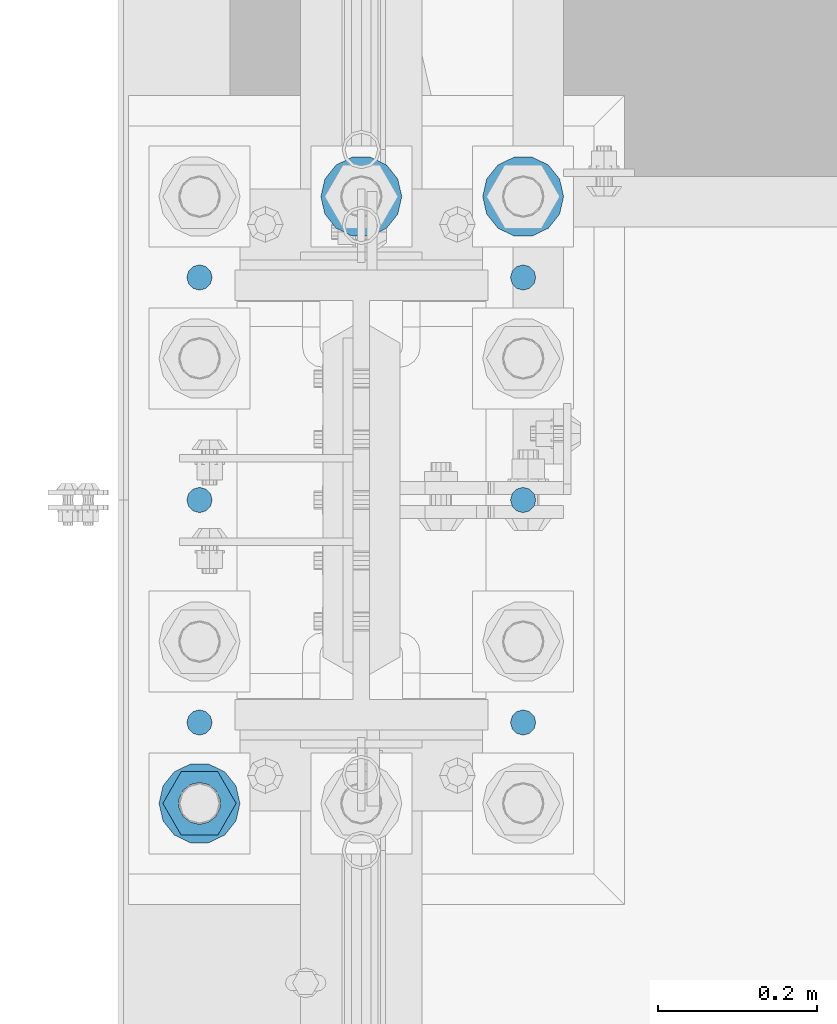
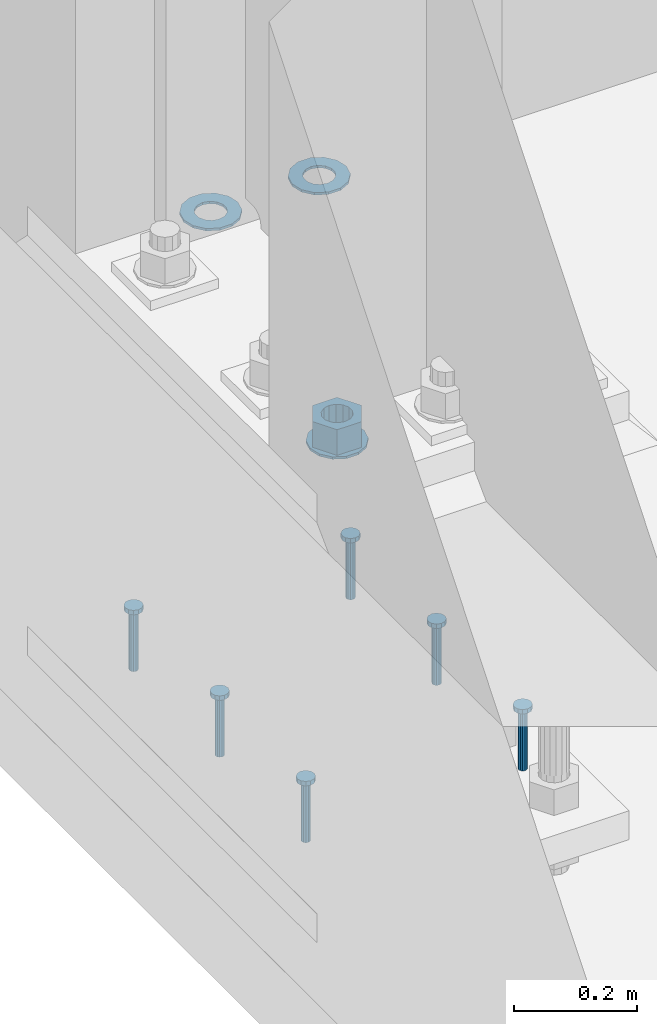
# One storey, part 834 of 1876: 10 columns, 1 element without a shape of its own.
"""IFC2X3 building model written with IfcOpenShell, lengths in millimetres."""

from ifc_helpers import new_model, si_unit, frame, origin_with_axes, place, context, subcontext, project, spatial, faceted_brep, material, type_object, element, aggregate, save


model = new_model("IFC2X3")

# Units and contexts
model_context = context("Model", 3, precision=1e-05, world=origin_with_axes())
body_context = subcontext(model_context, "Body", "Model", "MODEL_VIEW")
ifc_project = project(units=[si_unit("LENGTHUNIT", "METRE", prefix="MILLI"), si_unit("AREAUNIT", "SQUARE_METRE"), si_unit("VOLUMEUNIT", "CUBIC_METRE"), si_unit("MASSUNIT", "GRAM", prefix="KILO"), si_unit("TIMEUNIT", "SECOND"), si_unit("PLANEANGLEUNIT", "RADIAN"), si_unit("SOLIDANGLEUNIT", "STERADIAN"), si_unit("THERMODYNAMICTEMPERATUREUNIT", "DEGREE_CELSIUS"), si_unit("LUMINOUSINTENSITYUNIT", "LUMEN")], contexts=[model_context])

# Site, building, storey
site_placement = place(None, origin_with_axes())
site = spatial("IfcSite", under=ifc_project, at=site_placement, CompositionType="ELEMENT")
building_placement = place(site_placement, origin_with_axes())
building = spatial("IfcBuilding", under=site, at=building_placement, Name="Undefined", CompositionType="ELEMENT")
storey_placement = place(building_placement, origin_with_axes())
storey = spatial("IfcBuildingStorey", under=building, at=storey_placement, Name="Undefined", CompositionType="ELEMENT", Elevation=0.0)

# Assembly, columns
assembly_placement = place(storey_placement, origin_with_axes())
assembly = element("IfcElementAssembly", 1, at=assembly_placement, inside=storey, Name="TEMPLATE", AssemblyPlace="NOTDEFINED", PredefinedType="RIGID_FRAME")
ifc_material_1 = material(Name="STEEL/F436")
column_type_1 = type_object("IfcColumnType", Name="2_WASHER", PredefinedType="NOTDEFINED")
column_1_placement = place(assembly_placement, frame((0.0, 1905.0, 38.1), z_axis=(0.0, -1.0, 0.0), x_axis=(0.0, 0.0, -1.0)))
column_1 = element("IfcColumn", 2, at=column_1_placement, type_object=column_type_1, material=ifc_material_1, Name="WASHER", ObjectType="2_WASHER", context=body_context, shape_type="Brep", body=[
    faceted_brep([(0.0, -50.7999992370605, 9.09494701772928e-13), (0.0, -45.7692178020588, -22.0412936161442), (4.7625, -45.7692178020588, -22.0412936161442), (4.7625, -50.7999992370605, 9.09494701772928e-13), (0.0, -31.6732814587394, -39.7170387128856), (4.7625, -31.6732814587394, -39.7170387128856), (0.0, -11.3040632752118, -49.5263371950259), (4.7625, -11.3040632752118, -49.5263371950259), (0.0, 11.30406327521, -49.5263371950264), (4.7625, 11.30406327521, -49.5263371950264), (0.0, 31.6732814587385, -39.7170387128867), (4.7625, 31.6732814587385, -39.7170387128867), (0.0, 45.7692178020579, -22.041293616146), (4.7625, 45.7692178020579, -22.041293616146), (0.0, 50.7999992370605, -9.09494701772928e-13), (4.7625, 50.7999992370605, -9.09494701772928e-13), (0.0, 45.7692178020588, 22.0412936161442), (4.7625, 45.7692178020588, 22.0412936161442), (0.0, 31.6732814587394, 39.7170387128856), (4.7625, 31.6732814587394, 39.7170387128856), (0.0, 11.3040632752118, 49.5263371950259), (4.7625, 11.3040632752118, 49.5263371950259), (0.0, -11.30406327521, 49.5263371950264), (4.7625, -11.30406327521, 49.5263371950264), (0.0, -31.6732814587385, 39.7170387128867), (4.7625, -31.6732814587385, 39.7170387128867), (0.0, -45.7692178020579, 22.041293616146), (4.7625, -45.7692178020579, 22.041293616146), (0.0, 0.0, 26.9869995117188), (0.0, 11.7093983825444, 24.3146012721213), (4.7625, 11.7093983825444, 24.3146012721213), (4.7625, 0.0, 26.9869995117188), (0.0, 21.0996520289491, 16.8262864224157), (4.7625, 21.0996520289491, 16.8262864224157), (0.0, 26.3108629296712, 6.00524193584533), (4.7625, 26.3108629296712, 6.00524193584533), (0.0, 26.3108629296712, -6.00524193584533), (4.7625, 26.3108629296712, -6.00524193584533), (0.0, 21.0996520289491, -16.8262864224157), (4.7625, 21.0996520289491, -16.8262864224157), (0.0, 11.7093983825444, -24.3146012721213), (4.7625, 11.7093983825444, -24.3146012721213), (0.0, 0.0, -26.9869995117188), (4.7625, 0.0, -26.9869995117188), (0.0, -11.7093983825444, -24.3146012721213), (4.7625, -11.7093983825444, -24.3146012721213), (0.0, -21.0996520289491, -16.8262864224157), (4.7625, -21.0996520289491, -16.8262864224157), (0.0, -26.3108629296712, -6.00524193584533), (4.7625, -26.3108629296712, -6.00524193584533), (0.0, -26.3108629296712, 6.00524193584533), (4.7625, -26.3108629296712, 6.00524193584533), (0.0, -21.0996520289491, 16.8262864224157), (4.7625, -21.0996520289491, 16.8262864224157), (0.0, -11.7093983825444, 24.3146012721213), (4.7625, -11.7093983825444, 24.3146012721213)], [[[0, 1, 2, 3]], [[1, 4, 5, 2]], [[4, 6, 7, 5]], [[6, 8, 9, 7]], [[8, 10, 11, 9]], [[10, 12, 13, 11]], [[12, 14, 15, 13]], [[14, 16, 17, 15]], [[16, 18, 19, 17]], [[18, 20, 21, 19]], [[20, 22, 23, 21]], [[22, 24, 25, 23]], [[24, 26, 27, 25]], [[26, 0, 3, 27]], [[28, 29, 30, 31]], [[29, 32, 33, 30]], [[32, 34, 35, 33]], [[34, 36, 37, 35]], [[36, 38, 39, 37]], [[38, 40, 41, 39]], [[40, 42, 43, 41]], [[42, 44, 45, 43]], [[44, 46, 47, 45]], [[46, 48, 49, 47]], [[48, 50, 51, 49]], [[50, 52, 53, 51]], [[52, 54, 55, 53]], [[54, 28, 31, 55]], [[5, 7, 9, 11, 13, 15, 17, 19, 21, 23, 25, 27, 3, 2], [33, 35, 37, 39, 41, 43, 45, 47, 49, 51, 53, 55, 31, 30]], [[26, 24, 22, 20, 18, 16, 14, 12, 10, 8, 6, 4, 1, 0], [54, 52, 50, 48, 46, 44, 42, 40, 38, 36, 34, 32, 29, 28]]]),
])
column_2_placement = place(assembly_placement, frame((203.2, 1905.0, 38.1), z_axis=(0.0, 1.0, 0.0), x_axis=(0.0, 0.0, -1.0)))
column_2 = element("IfcColumn", 3, at=column_2_placement, type_object=column_type_1, material=ifc_material_1, Name="WASHER", ObjectType="2_WASHER", context=body_context, shape_type="Brep", body=[
    faceted_brep([(0.0, -50.7999992370605, 9.09494701772928e-13), (0.0, -45.7692178020588, -22.0412936161442), (4.7625, -45.7692178020588, -22.0412936161442), (4.7625, -50.7999992370605, 9.09494701772928e-13), (0.0, -31.6732814587394, -39.7170387128856), (4.7625, -31.6732814587394, -39.7170387128856), (0.0, -11.3040632752118, -49.5263371950259), (4.7625, -11.3040632752118, -49.5263371950259), (0.0, 11.30406327521, -49.5263371950264), (4.7625, 11.30406327521, -49.5263371950264), (0.0, 31.6732814587385, -39.7170387128867), (4.7625, 31.6732814587385, -39.7170387128867), (0.0, 45.7692178020579, -22.041293616146), (4.7625, 45.7692178020579, -22.041293616146), (0.0, 50.7999992370605, -9.09494701772928e-13), (4.7625, 50.7999992370605, -9.09494701772928e-13), (0.0, 45.7692178020588, 22.0412936161442), (4.7625, 45.7692178020588, 22.0412936161442), (0.0, 31.6732814587394, 39.7170387128856), (4.7625, 31.6732814587394, 39.7170387128856), (0.0, 11.3040632752118, 49.5263371950259), (4.7625, 11.3040632752118, 49.5263371950259), (0.0, -11.30406327521, 49.5263371950264), (4.7625, -11.30406327521, 49.5263371950264), (0.0, -31.6732814587385, 39.7170387128867), (4.7625, -31.6732814587385, 39.7170387128867), (0.0, -45.7692178020579, 22.041293616146), (4.7625, -45.7692178020579, 22.041293616146), (0.0, 0.0, 26.9869995117188), (0.0, 11.7093983825444, 24.3146012721213), (4.7625, 11.7093983825444, 24.3146012721213), (4.7625, 0.0, 26.9869995117188), (0.0, 21.0996520289491, 16.8262864224157), (4.7625, 21.0996520289491, 16.8262864224157), (0.0, 26.3108629296712, 6.00524193584533), (4.7625, 26.3108629296712, 6.00524193584533), (0.0, 26.3108629296712, -6.00524193584533), (4.7625, 26.3108629296712, -6.00524193584533), (0.0, 21.0996520289491, -16.8262864224157), (4.7625, 21.0996520289491, -16.8262864224157), (0.0, 11.7093983825444, -24.3146012721213), (4.7625, 11.7093983825444, -24.3146012721213), (0.0, 0.0, -26.9869995117188), (4.7625, 0.0, -26.9869995117188), (0.0, -11.7093983825444, -24.3146012721213), (4.7625, -11.7093983825444, -24.3146012721213), (0.0, -21.0996520289491, -16.8262864224157), (4.7625, -21.0996520289491, -16.8262864224157), (0.0, -26.3108629296712, -6.00524193584533), (4.7625, -26.3108629296712, -6.00524193584533), (0.0, -26.3108629296712, 6.00524193584533), (4.7625, -26.3108629296712, 6.00524193584533), (0.0, -21.0996520289491, 16.8262864224157), (4.7625, -21.0996520289491, 16.8262864224157), (0.0, -11.7093983825444, 24.3146012721213), (4.7625, -11.7093983825444, 24.3146012721213)], [[[0, 1, 2, 3]], [[1, 4, 5, 2]], [[4, 6, 7, 5]], [[6, 8, 9, 7]], [[8, 10, 11, 9]], [[10, 12, 13, 11]], [[12, 14, 15, 13]], [[14, 16, 17, 15]], [[16, 18, 19, 17]], [[18, 20, 21, 19]], [[20, 22, 23, 21]], [[22, 24, 25, 23]], [[24, 26, 27, 25]], [[26, 0, 3, 27]], [[28, 29, 30, 31]], [[29, 32, 33, 30]], [[32, 34, 35, 33]], [[34, 36, 37, 35]], [[36, 38, 39, 37]], [[38, 40, 41, 39]], [[40, 42, 43, 41]], [[42, 44, 45, 43]], [[44, 46, 47, 45]], [[46, 48, 49, 47]], [[48, 50, 51, 49]], [[50, 52, 53, 51]], [[52, 54, 55, 53]], [[54, 28, 31, 55]], [[5, 7, 9, 11, 13, 15, 17, 19, 21, 23, 25, 27, 3, 2], [33, 35, 37, 39, 41, 43, 45, 47, 49, 51, 53, 55, 31, 30]], [[26, 24, 22, 20, 18, 16, 14, 12, 10, 8, 6, 4, 1, 0], [54, 52, 50, 48, 46, 44, 42, 40, 38, 36, 34, 32, 29, 28]]]),
])
column_3_placement = place(assembly_placement, frame((-203.2, 1143.0, 119.0625), z_axis=(0.0, -1.0, 0.0), x_axis=(0.0, 0.0, -1.0)))
column_3 = element("IfcColumn", 4, at=column_3_placement, type_object=column_type_1, material=ifc_material_1, Name="WASHER", ObjectType="2_WASHER", context=body_context, shape_type="Brep", body=[
    faceted_brep([(0.0, -50.7999992370605, 9.09494701772928e-13), (0.0, -45.7692178020588, -22.0412936161442), (4.7625, -45.7692178020588, -22.0412936161442), (4.7625, -50.7999992370605, 9.09494701772928e-13), (0.0, -31.6732814587394, -39.7170387128856), (4.7625, -31.6732814587394, -39.7170387128856), (0.0, -11.3040632752118, -49.5263371950259), (4.7625, -11.3040632752118, -49.5263371950259), (0.0, 11.30406327521, -49.5263371950264), (4.7625, 11.30406327521, -49.5263371950264), (0.0, 31.6732814587385, -39.7170387128867), (4.7625, 31.6732814587385, -39.7170387128867), (0.0, 45.7692178020579, -22.041293616146), (4.7625, 45.7692178020579, -22.041293616146), (0.0, 50.7999992370605, -9.09494701772928e-13), (4.7625, 50.7999992370605, -9.09494701772928e-13), (0.0, 45.7692178020588, 22.0412936161442), (4.7625, 45.7692178020588, 22.0412936161442), (0.0, 31.6732814587394, 39.7170387128856), (4.7625, 31.6732814587394, 39.7170387128856), (0.0, 11.3040632752118, 49.5263371950259), (4.7625, 11.3040632752118, 49.5263371950259), (0.0, -11.30406327521, 49.5263371950264), (4.7625, -11.30406327521, 49.5263371950264), (0.0, -31.6732814587385, 39.7170387128867), (4.7625, -31.6732814587385, 39.7170387128867), (0.0, -45.7692178020579, 22.041293616146), (4.7625, -45.7692178020579, 22.041293616146), (0.0, 0.0, 26.9869995117188), (0.0, 11.7093983825444, 24.3146012721213), (4.7625, 11.7093983825444, 24.3146012721213), (4.7625, 0.0, 26.9869995117188), (0.0, 21.0996520289491, 16.8262864224157), (4.7625, 21.0996520289491, 16.8262864224157), (0.0, 26.3108629296712, 6.00524193584533), (4.7625, 26.3108629296712, 6.00524193584533), (0.0, 26.3108629296712, -6.00524193584533), (4.7625, 26.3108629296712, -6.00524193584533), (0.0, 21.0996520289491, -16.8262864224157), (4.7625, 21.0996520289491, -16.8262864224157), (0.0, 11.7093983825444, -24.3146012721213), (4.7625, 11.7093983825444, -24.3146012721213), (0.0, 0.0, -26.9869995117188), (4.7625, 0.0, -26.9869995117188), (0.0, -11.7093983825444, -24.3146012721213), (4.7625, -11.7093983825444, -24.3146012721213), (0.0, -21.0996520289491, -16.8262864224157), (4.7625, -21.0996520289491, -16.8262864224157), (0.0, -26.3108629296712, -6.00524193584533), (4.7625, -26.3108629296712, -6.00524193584533), (0.0, -26.3108629296712, 6.00524193584533), (4.7625, -26.3108629296712, 6.00524193584533), (0.0, -21.0996520289491, 16.8262864224157), (4.7625, -21.0996520289491, 16.8262864224157), (0.0, -11.7093983825444, 24.3146012721213), (4.7625, -11.7093983825444, 24.3146012721213)], [[[0, 1, 2, 3]], [[1, 4, 5, 2]], [[4, 6, 7, 5]], [[6, 8, 9, 7]], [[8, 10, 11, 9]], [[10, 12, 13, 11]], [[12, 14, 15, 13]], [[14, 16, 17, 15]], [[16, 18, 19, 17]], [[18, 20, 21, 19]], [[20, 22, 23, 21]], [[22, 24, 25, 23]], [[24, 26, 27, 25]], [[26, 0, 3, 27]], [[28, 29, 30, 31]], [[29, 32, 33, 30]], [[32, 34, 35, 33]], [[34, 36, 37, 35]], [[36, 38, 39, 37]], [[38, 40, 41, 39]], [[40, 42, 43, 41]], [[42, 44, 45, 43]], [[44, 46, 47, 45]], [[46, 48, 49, 47]], [[48, 50, 51, 49]], [[50, 52, 53, 51]], [[52, 54, 55, 53]], [[54, 28, 31, 55]], [[5, 7, 9, 11, 13, 15, 17, 19, 21, 23, 25, 27, 3, 2], [33, 35, 37, 39, 41, 43, 45, 47, 49, 51, 53, 55, 31, 30]], [[26, 24, 22, 20, 18, 16, 14, 12, 10, 8, 6, 4, 1, 0], [54, 52, 50, 48, 46, 44, 42, 40, 38, 36, 34, 32, 29, 28]]]),
])
ifc_material_2 = material(Name="STEEL/A108")
column_type_2 = type_object("IfcColumnType", Name="5/8-DIA_HEADED ANCHOR STUD", PredefinedType="NOTDEFINED")
column_4_placement = place(assembly_placement, frame((203.2, 1803.4, -736.6), z_axis=(1.0, 0.0, 0.0), x_axis=(0.0, 0.0, 1.0)))
column_4 = element("IfcColumn", 5, at=column_4_placement, type_object=column_type_2, material=ifc_material_2, Name="HEADED ANCHOR STUD", ObjectType="5/8-DIA_HEADED ANCHOR STUD", context=body_context, shape_type="Brep", body=[
    faceted_brep([(0.0, -7.94000005722046, 0.0), (0.0, -6.86999988555908, -3.97000002861023), (116.84, -6.86999988555908, -3.97000002861023), (116.84, -7.94000005722046, 0.0), (0.0, -3.97000002861023, -6.86999988555908), (116.84, -3.97000002861023, -6.86999988555908), (0.0, 0.0, -7.94000005722046), (116.84, 0.0, -7.94000005722046), (0.0, 3.97000002861023, -6.86999988555908), (116.84, 3.97000002861023, -6.86999988555908), (0.0, 6.86999988555908, -3.97000002861023), (116.84, 6.86999988555908, -3.97000002861023), (0.0, 7.94000005722046, 0.0), (116.84, 7.94000005722046, 0.0), (0.0, 6.86999988555908, 3.97000002861023), (116.84, 6.86999988555908, 3.97000002861023), (0.0, 3.97000002861023, 6.86999988555908), (116.84, 3.97000002861023, 6.86999988555908), (0.0, 0.0, 7.94000005722046), (116.84, 0.0, 7.94000005722046), (0.0, -3.97000002861023, 6.86999988555908), (116.84, -3.97000002861023, 6.86999988555908), (0.0, -6.86999988555908, 3.97000002861023), (116.84, -6.86999988555908, 3.97000002861023), (118.11, -13.75, -7.94000005722046), (118.11, -15.8800001144409, 0.0), (118.11, -7.94000005722046, -13.75), (118.11, 0.0, -15.8800001144409), (118.11, 7.94000005722046, -13.75), (118.11, 13.75, -7.94000005722046), (118.11, 15.8800001144409, 0.0), (118.11, 13.75, 7.94000005722046), (118.11, 7.94000005722046, 13.75), (118.11, 0.0, 15.8800001144409), (118.11, -7.94000005722046, 13.75), (118.11, -13.75, 7.94000005722046), (127.0, -13.75, -7.94000005722046), (127.0, -15.8800001144409, 0.0), (127.0, -7.94000005722046, -13.75), (127.0, 0.0, -15.8800001144409), (127.0, 7.94000005722046, -13.75), (127.0, 13.75, -7.94000005722046), (127.0, 15.8800001144409, 0.0), (127.0, 13.75, 7.94000005722046), (127.0, 7.94000005722046, 13.75), (127.0, 0.0, 15.8800001144409), (127.0, -7.94000005722046, 13.75), (127.0, -13.75, 7.94000005722046)], [[[0, 1, 2, 3]], [[1, 4, 5, 2]], [[4, 6, 7, 5]], [[6, 8, 9, 7]], [[8, 10, 11, 9]], [[10, 12, 13, 11]], [[12, 14, 15, 13]], [[14, 16, 17, 15]], [[16, 18, 19, 17]], [[18, 20, 21, 19]], [[20, 22, 23, 21]], [[22, 0, 3, 23]], [[22, 20, 18, 16, 14, 12, 10, 8, 6, 4, 1, 0]], [[3, 2, 24, 25]], [[2, 5, 26, 24]], [[5, 7, 27, 26]], [[7, 9, 28, 27]], [[9, 11, 29, 28]], [[11, 13, 30, 29]], [[13, 15, 31, 30]], [[15, 17, 32, 31]], [[17, 19, 33, 32]], [[19, 21, 34, 33]], [[21, 23, 35, 34]], [[23, 3, 25, 35]], [[25, 24, 36, 37]], [[24, 26, 38, 36]], [[26, 27, 39, 38]], [[27, 28, 40, 39]], [[28, 29, 41, 40]], [[29, 30, 42, 41]], [[30, 31, 43, 42]], [[31, 32, 44, 43]], [[32, 33, 45, 44]], [[33, 34, 46, 45]], [[34, 35, 47, 46]], [[35, 25, 37, 47]], [[38, 39, 40, 41, 42, 43, 44, 45, 46, 47, 37, 36]]]),
])
column_5_placement = place(assembly_placement, frame((203.2, 1244.6, -736.6), z_axis=(1.0, 0.0, 0.0), x_axis=(0.0, 0.0, 1.0)))
column_5 = element("IfcColumn", 6, at=column_5_placement, type_object=column_type_2, material=ifc_material_2, Name="HEADED ANCHOR STUD", ObjectType="5/8-DIA_HEADED ANCHOR STUD", context=body_context, shape_type="Brep", body=[
    faceted_brep([(0.0, -7.94000005722046, 0.0), (0.0, -6.86999988555908, -3.97000002861023), (116.84, -6.86999988555908, -3.97000002861023), (116.84, -7.94000005722046, 0.0), (0.0, -3.97000002861023, -6.86999988555908), (116.84, -3.97000002861023, -6.86999988555908), (0.0, 0.0, -7.94000005722046), (116.84, 0.0, -7.94000005722046), (0.0, 3.97000002861023, -6.86999988555908), (116.84, 3.97000002861023, -6.86999988555908), (0.0, 6.86999988555908, -3.97000002861023), (116.84, 6.86999988555908, -3.97000002861023), (0.0, 7.94000005722046, 0.0), (116.84, 7.94000005722046, 0.0), (0.0, 6.86999988555908, 3.97000002861023), (116.84, 6.86999988555908, 3.97000002861023), (0.0, 3.97000002861023, 6.86999988555908), (116.84, 3.97000002861023, 6.86999988555908), (0.0, 0.0, 7.94000005722046), (116.84, 0.0, 7.94000005722046), (0.0, -3.97000002861023, 6.86999988555908), (116.84, -3.97000002861023, 6.86999988555908), (0.0, -6.86999988555908, 3.97000002861023), (116.84, -6.86999988555908, 3.97000002861023), (118.11, -13.75, -7.94000005722046), (118.11, -15.8800001144409, 0.0), (118.11, -7.94000005722046, -13.75), (118.11, 0.0, -15.8800001144409), (118.11, 7.94000005722046, -13.75), (118.11, 13.75, -7.94000005722046), (118.11, 15.8800001144409, 0.0), (118.11, 13.75, 7.94000005722046), (118.11, 7.94000005722046, 13.75), (118.11, 0.0, 15.8800001144409), (118.11, -7.94000005722046, 13.75), (118.11, -13.75, 7.94000005722046), (127.0, -13.75, -7.94000005722046), (127.0, -15.8800001144409, 0.0), (127.0, -7.94000005722046, -13.75), (127.0, 0.0, -15.8800001144409), (127.0, 7.94000005722046, -13.75), (127.0, 13.75, -7.94000005722046), (127.0, 15.8800001144409, 0.0), (127.0, 13.75, 7.94000005722046), (127.0, 7.94000005722046, 13.75), (127.0, 0.0, 15.8800001144409), (127.0, -7.94000005722046, 13.75), (127.0, -13.75, 7.94000005722046)], [[[0, 1, 2, 3]], [[1, 4, 5, 2]], [[4, 6, 7, 5]], [[6, 8, 9, 7]], [[8, 10, 11, 9]], [[10, 12, 13, 11]], [[12, 14, 15, 13]], [[14, 16, 17, 15]], [[16, 18, 19, 17]], [[18, 20, 21, 19]], [[20, 22, 23, 21]], [[22, 0, 3, 23]], [[22, 20, 18, 16, 14, 12, 10, 8, 6, 4, 1, 0]], [[3, 2, 24, 25]], [[2, 5, 26, 24]], [[5, 7, 27, 26]], [[7, 9, 28, 27]], [[9, 11, 29, 28]], [[11, 13, 30, 29]], [[13, 15, 31, 30]], [[15, 17, 32, 31]], [[17, 19, 33, 32]], [[19, 21, 34, 33]], [[21, 23, 35, 34]], [[23, 3, 25, 35]], [[25, 24, 36, 37]], [[24, 26, 38, 36]], [[26, 27, 39, 38]], [[27, 28, 40, 39]], [[28, 29, 41, 40]], [[29, 30, 42, 41]], [[30, 31, 43, 42]], [[31, 32, 44, 43]], [[32, 33, 45, 44]], [[33, 34, 46, 45]], [[34, 35, 47, 46]], [[35, 25, 37, 47]], [[38, 39, 40, 41, 42, 43, 44, 45, 46, 47, 37, 36]]]),
])
column_6_placement = place(assembly_placement, frame((203.2, 1524.0, -736.6), z_axis=(1.0, 0.0, 0.0), x_axis=(0.0, 0.0, 1.0)))
column_6 = element("IfcColumn", 7, at=column_6_placement, type_object=column_type_2, material=ifc_material_2, Name="HEADED ANCHOR STUD", ObjectType="5/8-DIA_HEADED ANCHOR STUD", context=body_context, shape_type="Brep", body=[
    faceted_brep([(0.0, -7.94000005722046, 0.0), (0.0, -6.86999988555908, -3.97000002861023), (116.84, -6.86999988555908, -3.97000002861023), (116.84, -7.94000005722046, 0.0), (0.0, -3.97000002861023, -6.86999988555908), (116.84, -3.97000002861023, -6.86999988555908), (0.0, 0.0, -7.94000005722046), (116.84, 0.0, -7.94000005722046), (0.0, 3.97000002861023, -6.86999988555908), (116.84, 3.97000002861023, -6.86999988555908), (0.0, 6.86999988555908, -3.97000002861023), (116.84, 6.86999988555908, -3.97000002861023), (0.0, 7.94000005722046, 0.0), (116.84, 7.94000005722046, 0.0), (0.0, 6.86999988555908, 3.97000002861023), (116.84, 6.86999988555908, 3.97000002861023), (0.0, 3.97000002861023, 6.86999988555908), (116.84, 3.97000002861023, 6.86999988555908), (0.0, 0.0, 7.94000005722046), (116.84, 0.0, 7.94000005722046), (0.0, -3.97000002861023, 6.86999988555908), (116.84, -3.97000002861023, 6.86999988555908), (0.0, -6.86999988555908, 3.97000002861023), (116.84, -6.86999988555908, 3.97000002861023), (118.11, -13.75, -7.94000005722046), (118.11, -15.8800001144409, 0.0), (118.11, -7.94000005722046, -13.75), (118.11, 0.0, -15.8800001144409), (118.11, 7.94000005722046, -13.75), (118.11, 13.75, -7.94000005722046), (118.11, 15.8800001144409, 0.0), (118.11, 13.75, 7.94000005722046), (118.11, 7.94000005722046, 13.75), (118.11, 0.0, 15.8800001144409), (118.11, -7.94000005722046, 13.75), (118.11, -13.75, 7.94000005722046), (127.0, -13.75, -7.94000005722046), (127.0, -15.8800001144409, 0.0), (127.0, -7.94000005722046, -13.75), (127.0, 0.0, -15.8800001144409), (127.0, 7.94000005722046, -13.75), (127.0, 13.75, -7.94000005722046), (127.0, 15.8800001144409, 0.0), (127.0, 13.75, 7.94000005722046), (127.0, 7.94000005722046, 13.75), (127.0, 0.0, 15.8800001144409), (127.0, -7.94000005722046, 13.75), (127.0, -13.75, 7.94000005722046)], [[[0, 1, 2, 3]], [[1, 4, 5, 2]], [[4, 6, 7, 5]], [[6, 8, 9, 7]], [[8, 10, 11, 9]], [[10, 12, 13, 11]], [[12, 14, 15, 13]], [[14, 16, 17, 15]], [[16, 18, 19, 17]], [[18, 20, 21, 19]], [[20, 22, 23, 21]], [[22, 0, 3, 23]], [[22, 20, 18, 16, 14, 12, 10, 8, 6, 4, 1, 0]], [[3, 2, 24, 25]], [[2, 5, 26, 24]], [[5, 7, 27, 26]], [[7, 9, 28, 27]], [[9, 11, 29, 28]], [[11, 13, 30, 29]], [[13, 15, 31, 30]], [[15, 17, 32, 31]], [[17, 19, 33, 32]], [[19, 21, 34, 33]], [[21, 23, 35, 34]], [[23, 3, 25, 35]], [[25, 24, 36, 37]], [[24, 26, 38, 36]], [[26, 27, 39, 38]], [[27, 28, 40, 39]], [[28, 29, 41, 40]], [[29, 30, 42, 41]], [[30, 31, 43, 42]], [[31, 32, 44, 43]], [[32, 33, 45, 44]], [[33, 34, 46, 45]], [[34, 35, 47, 46]], [[35, 25, 37, 47]], [[38, 39, 40, 41, 42, 43, 44, 45, 46, 47, 37, 36]]]),
])
column_7_placement = place(assembly_placement, frame((-203.2, 1803.4, -736.6), z_axis=(1.0, 0.0, 0.0), x_axis=(0.0, 0.0, 1.0)))
column_7 = element("IfcColumn", 8, at=column_7_placement, type_object=column_type_2, material=ifc_material_2, Name="HEADED ANCHOR STUD", ObjectType="5/8-DIA_HEADED ANCHOR STUD", context=body_context, shape_type="Brep", body=[
    faceted_brep([(0.0, -7.94000005722046, 0.0), (0.0, -6.86999988555908, -3.97000002861023), (116.84, -6.86999988555908, -3.97000002861023), (116.84, -7.94000005722046, 0.0), (0.0, -3.97000002861023, -6.86999988555908), (116.84, -3.97000002861023, -6.86999988555908), (0.0, 0.0, -7.94000005722046), (116.84, 0.0, -7.94000005722046), (0.0, 3.97000002861023, -6.86999988555908), (116.84, 3.97000002861023, -6.86999988555908), (0.0, 6.86999988555908, -3.97000002861023), (116.84, 6.86999988555908, -3.97000002861023), (0.0, 7.94000005722046, 0.0), (116.84, 7.94000005722046, 0.0), (0.0, 6.86999988555908, 3.97000002861023), (116.84, 6.86999988555908, 3.97000002861023), (0.0, 3.97000002861023, 6.86999988555908), (116.84, 3.97000002861023, 6.86999988555908), (0.0, 0.0, 7.94000005722046), (116.84, 0.0, 7.94000005722046), (0.0, -3.97000002861023, 6.86999988555908), (116.84, -3.97000002861023, 6.86999988555908), (0.0, -6.86999988555908, 3.97000002861023), (116.84, -6.86999988555908, 3.97000002861023), (118.11, -13.75, -7.94000005722046), (118.11, -15.8800001144409, 0.0), (118.11, -7.94000005722046, -13.75), (118.11, 0.0, -15.8800001144409), (118.11, 7.94000005722046, -13.75), (118.11, 13.75, -7.94000005722046), (118.11, 15.8800001144409, 0.0), (118.11, 13.75, 7.94000005722046), (118.11, 7.94000005722046, 13.75), (118.11, 0.0, 15.8800001144409), (118.11, -7.94000005722046, 13.75), (118.11, -13.75, 7.94000005722046), (127.0, -13.75, -7.94000005722046), (127.0, -15.8800001144409, 0.0), (127.0, -7.94000005722046, -13.75), (127.0, 0.0, -15.8800001144409), (127.0, 7.94000005722046, -13.75), (127.0, 13.75, -7.94000005722046), (127.0, 15.8800001144409, 0.0), (127.0, 13.75, 7.94000005722046), (127.0, 7.94000005722046, 13.75), (127.0, 0.0, 15.8800001144409), (127.0, -7.94000005722046, 13.75), (127.0, -13.75, 7.94000005722046)], [[[0, 1, 2, 3]], [[1, 4, 5, 2]], [[4, 6, 7, 5]], [[6, 8, 9, 7]], [[8, 10, 11, 9]], [[10, 12, 13, 11]], [[12, 14, 15, 13]], [[14, 16, 17, 15]], [[16, 18, 19, 17]], [[18, 20, 21, 19]], [[20, 22, 23, 21]], [[22, 0, 3, 23]], [[22, 20, 18, 16, 14, 12, 10, 8, 6, 4, 1, 0]], [[3, 2, 24, 25]], [[2, 5, 26, 24]], [[5, 7, 27, 26]], [[7, 9, 28, 27]], [[9, 11, 29, 28]], [[11, 13, 30, 29]], [[13, 15, 31, 30]], [[15, 17, 32, 31]], [[17, 19, 33, 32]], [[19, 21, 34, 33]], [[21, 23, 35, 34]], [[23, 3, 25, 35]], [[25, 24, 36, 37]], [[24, 26, 38, 36]], [[26, 27, 39, 38]], [[27, 28, 40, 39]], [[28, 29, 41, 40]], [[29, 30, 42, 41]], [[30, 31, 43, 42]], [[31, 32, 44, 43]], [[32, 33, 45, 44]], [[33, 34, 46, 45]], [[34, 35, 47, 46]], [[35, 25, 37, 47]], [[38, 39, 40, 41, 42, 43, 44, 45, 46, 47, 37, 36]]]),
])
column_8_placement = place(assembly_placement, frame((-203.2, 1244.6, -736.6), z_axis=(1.0, 0.0, 0.0), x_axis=(0.0, 0.0, 1.0)))
column_8 = element("IfcColumn", 9, at=column_8_placement, type_object=column_type_2, material=ifc_material_2, Name="HEADED ANCHOR STUD", ObjectType="5/8-DIA_HEADED ANCHOR STUD", context=body_context, shape_type="Brep", body=[
    faceted_brep([(0.0, -7.94000005722046, 0.0), (0.0, -6.86999988555908, -3.97000002861023), (116.84, -6.86999988555908, -3.97000002861023), (116.84, -7.94000005722046, 0.0), (0.0, -3.97000002861023, -6.86999988555908), (116.84, -3.97000002861023, -6.86999988555908), (0.0, 0.0, -7.94000005722046), (116.84, 0.0, -7.94000005722046), (0.0, 3.97000002861023, -6.86999988555908), (116.84, 3.97000002861023, -6.86999988555908), (0.0, 6.86999988555908, -3.97000002861023), (116.84, 6.86999988555908, -3.97000002861023), (0.0, 7.94000005722046, 0.0), (116.84, 7.94000005722046, 0.0), (0.0, 6.86999988555908, 3.97000002861023), (116.84, 6.86999988555908, 3.97000002861023), (0.0, 3.97000002861023, 6.86999988555908), (116.84, 3.97000002861023, 6.86999988555908), (0.0, 0.0, 7.94000005722046), (116.84, 0.0, 7.94000005722046), (0.0, -3.97000002861023, 6.86999988555908), (116.84, -3.97000002861023, 6.86999988555908), (0.0, -6.86999988555908, 3.97000002861023), (116.84, -6.86999988555908, 3.97000002861023), (118.11, -13.75, -7.94000005722046), (118.11, -15.8800001144409, 0.0), (118.11, -7.94000005722046, -13.75), (118.11, 0.0, -15.8800001144409), (118.11, 7.94000005722046, -13.75), (118.11, 13.75, -7.94000005722046), (118.11, 15.8800001144409, 0.0), (118.11, 13.75, 7.94000005722046), (118.11, 7.94000005722046, 13.75), (118.11, 0.0, 15.8800001144409), (118.11, -7.94000005722046, 13.75), (118.11, -13.75, 7.94000005722046), (127.0, -13.75, -7.94000005722046), (127.0, -15.8800001144409, 0.0), (127.0, -7.94000005722046, -13.75), (127.0, 0.0, -15.8800001144409), (127.0, 7.94000005722046, -13.75), (127.0, 13.75, -7.94000005722046), (127.0, 15.8800001144409, 0.0), (127.0, 13.75, 7.94000005722046), (127.0, 7.94000005722046, 13.75), (127.0, 0.0, 15.8800001144409), (127.0, -7.94000005722046, 13.75), (127.0, -13.75, 7.94000005722046)], [[[0, 1, 2, 3]], [[1, 4, 5, 2]], [[4, 6, 7, 5]], [[6, 8, 9, 7]], [[8, 10, 11, 9]], [[10, 12, 13, 11]], [[12, 14, 15, 13]], [[14, 16, 17, 15]], [[16, 18, 19, 17]], [[18, 20, 21, 19]], [[20, 22, 23, 21]], [[22, 0, 3, 23]], [[22, 20, 18, 16, 14, 12, 10, 8, 6, 4, 1, 0]], [[3, 2, 24, 25]], [[2, 5, 26, 24]], [[5, 7, 27, 26]], [[7, 9, 28, 27]], [[9, 11, 29, 28]], [[11, 13, 30, 29]], [[13, 15, 31, 30]], [[15, 17, 32, 31]], [[17, 19, 33, 32]], [[19, 21, 34, 33]], [[21, 23, 35, 34]], [[23, 3, 25, 35]], [[25, 24, 36, 37]], [[24, 26, 38, 36]], [[26, 27, 39, 38]], [[27, 28, 40, 39]], [[28, 29, 41, 40]], [[29, 30, 42, 41]], [[30, 31, 43, 42]], [[31, 32, 44, 43]], [[32, 33, 45, 44]], [[33, 34, 46, 45]], [[34, 35, 47, 46]], [[35, 25, 37, 47]], [[38, 39, 40, 41, 42, 43, 44, 45, 46, 47, 37, 36]]]),
])
column_9_placement = place(assembly_placement, frame((-203.2, 1524.0, -736.6), z_axis=(1.0, 0.0, 0.0), x_axis=(0.0, 0.0, 1.0)))
column_9 = element("IfcColumn", 10, at=column_9_placement, type_object=column_type_2, material=ifc_material_2, Name="HEADED ANCHOR STUD", ObjectType="5/8-DIA_HEADED ANCHOR STUD", context=body_context, shape_type="Brep", body=[
    faceted_brep([(0.0, -7.94000005722046, 0.0), (0.0, -6.86999988555908, -3.97000002861023), (116.84, -6.86999988555908, -3.97000002861023), (116.84, -7.94000005722046, 0.0), (0.0, -3.97000002861023, -6.86999988555908), (116.84, -3.97000002861023, -6.86999988555908), (0.0, 0.0, -7.94000005722046), (116.84, 0.0, -7.94000005722046), (0.0, 3.97000002861023, -6.86999988555908), (116.84, 3.97000002861023, -6.86999988555908), (0.0, 6.86999988555908, -3.97000002861023), (116.84, 6.86999988555908, -3.97000002861023), (0.0, 7.94000005722046, 0.0), (116.84, 7.94000005722046, 0.0), (0.0, 6.86999988555908, 3.97000002861023), (116.84, 6.86999988555908, 3.97000002861023), (0.0, 3.97000002861023, 6.86999988555908), (116.84, 3.97000002861023, 6.86999988555908), (0.0, 0.0, 7.94000005722046), (116.84, 0.0, 7.94000005722046), (0.0, -3.97000002861023, 6.86999988555908), (116.84, -3.97000002861023, 6.86999988555908), (0.0, -6.86999988555908, 3.97000002861023), (116.84, -6.86999988555908, 3.97000002861023), (118.11, -13.75, -7.94000005722046), (118.11, -15.8800001144409, 0.0), (118.11, -7.94000005722046, -13.75), (118.11, 0.0, -15.8800001144409), (118.11, 7.94000005722046, -13.75), (118.11, 13.75, -7.94000005722046), (118.11, 15.8800001144409, 0.0), (118.11, 13.75, 7.94000005722046), (118.11, 7.94000005722046, 13.75), (118.11, 0.0, 15.8800001144409), (118.11, -7.94000005722046, 13.75), (118.11, -13.75, 7.94000005722046), (127.0, -13.75, -7.94000005722046), (127.0, -15.8800001144409, 0.0), (127.0, -7.94000005722046, -13.75), (127.0, 0.0, -15.8800001144409), (127.0, 7.94000005722046, -13.75), (127.0, 13.75, -7.94000005722046), (127.0, 15.8800001144409, 0.0), (127.0, 13.75, 7.94000005722046), (127.0, 7.94000005722046, 13.75), (127.0, 0.0, 15.8800001144409), (127.0, -7.94000005722046, 13.75), (127.0, -13.75, 7.94000005722046)], [[[0, 1, 2, 3]], [[1, 4, 5, 2]], [[4, 6, 7, 5]], [[6, 8, 9, 7]], [[8, 10, 11, 9]], [[10, 12, 13, 11]], [[12, 14, 15, 13]], [[14, 16, 17, 15]], [[16, 18, 19, 17]], [[18, 20, 21, 19]], [[20, 22, 23, 21]], [[22, 0, 3, 23]], [[22, 20, 18, 16, 14, 12, 10, 8, 6, 4, 1, 0]], [[3, 2, 24, 25]], [[2, 5, 26, 24]], [[5, 7, 27, 26]], [[7, 9, 28, 27]], [[9, 11, 29, 28]], [[11, 13, 30, 29]], [[13, 15, 31, 30]], [[15, 17, 32, 31]], [[17, 19, 33, 32]], [[19, 21, 34, 33]], [[21, 23, 35, 34]], [[23, 3, 25, 35]], [[25, 24, 36, 37]], [[24, 26, 38, 36]], [[26, 27, 39, 38]], [[27, 28, 40, 39]], [[28, 29, 41, 40]], [[29, 30, 42, 41]], [[30, 31, 43, 42]], [[31, 32, 44, 43]], [[32, 33, 45, 44]], [[33, 34, 46, 45]], [[34, 35, 47, 46]], [[35, 25, 37, 47]], [[38, 39, 40, 41, 42, 43, 44, 45, 46, 47, 37, 36]]]),
])
ifc_material_3 = material(Name="STEEL/A563")
column_type_3 = type_object("IfcColumnType", Name="2_HEAVY_HEX_NUT", PredefinedType="NOTDEFINED")
column_10_placement = place(assembly_placement, frame((-203.2, 1143.0, 169.8625), z_axis=(0.0, -1.0, 0.0), x_axis=(0.0, 0.0, -1.0)))
column_10 = element("IfcColumn", 11, at=column_10_placement, type_object=column_type_3, material=ifc_material_3, Name="NUT", ObjectType="2_HEAVY_HEX_NUT", context=body_context, shape_type="Brep", body=[
    faceted_brep([(0.0, -46.0369987487793, 9.09494701772928e-13), (0.0, -23.0184993743896, -39.869213104248), (50.8, -23.0184993743896, -39.869213104248), (50.8, -46.0369987487793, 9.09494701772928e-13), (0.0, 23.0184993743896, -39.869213104248), (50.8, 23.0184993743896, -39.869213104248), (0.0, 46.0369987487793, -9.09494701772928e-13), (50.8, 46.0369987487793, -9.09494701772928e-13), (0.0, 23.0184993743896, 39.869213104248), (50.8, 23.0184993743896, 39.869213104248), (0.0, -23.0184993743896, 39.869213104248), (50.8, -23.0184993743896, 39.869213104248), (0.0, 0.0, 26.1940002441406), (0.0, 11.3650617044514, 23.5999013092769), (50.8, 11.3650617044513, 23.5999013092771), (50.8, 0.0, 26.1940002441406), (0.0, 20.4791109456437, 16.3316083006703), (50.8, 20.4791109456439, 16.3316083006703), (0.0, 25.5370200498346, 5.82867859874477), (50.8, 25.5370200498343, 5.82867859874455), (0.0, 25.5370200498346, -5.82867859874477), (50.8, 25.5370200498343, -5.82867859874455), (0.0, 20.4791109456437, -16.3316083006703), (50.8, 20.4791109456439, -16.3316083006703), (0.0, 11.3650617044514, -23.5999013092769), (50.8, 11.3650617044514, -23.5999013092771), (0.0, 0.0, -26.1940002441406), (50.8, 0.0, -26.1940002441406), (0.0, -11.3650617044514, -23.5999013092769), (50.8, -11.3650617044513, -23.5999013092771), (0.0, -20.4791109456437, -16.3316083006703), (50.8, -20.4791109456439, -16.3316083006703), (0.0, -25.5370200498346, -5.82867859874477), (50.8, -25.5370200498343, -5.82867859874455), (0.0, -25.5370200498346, 5.82867859874477), (50.8, -25.5370200498343, 5.82867859874455), (0.0, -20.4791109456437, 16.3316083006703), (50.8, -20.4791109456439, 16.3316083006703), (0.0, -11.3650617044514, 23.5999013092769), (50.8, -11.3650617044514, 23.5999013092771)], [[[0, 1, 2, 3]], [[1, 4, 5, 2]], [[4, 6, 7, 5]], [[6, 8, 9, 7]], [[8, 10, 11, 9]], [[10, 0, 3, 11]], [[12, 13, 14, 15]], [[13, 16, 17, 14]], [[16, 18, 19, 17]], [[18, 20, 21, 19]], [[20, 22, 23, 21]], [[22, 24, 25, 23]], [[24, 26, 27, 25]], [[26, 28, 29, 27]], [[28, 30, 31, 29]], [[30, 32, 33, 31]], [[32, 34, 35, 33]], [[34, 36, 37, 35]], [[36, 38, 39, 37]], [[38, 12, 15, 39]], [[5, 7, 9, 11, 3, 2], [17, 19, 21, 23, 25, 27, 29, 31, 33, 35, 37, 39, 15, 14]], [[10, 8, 6, 4, 1, 0], [38, 36, 34, 32, 30, 28, 26, 24, 22, 20, 18, 16, 13, 12]]]),
])
aggregate(assembly, [column_1, column_2, column_4, column_5, column_6, column_7, column_8, column_9, column_10, column_3])

save(model, "model.ifc")
